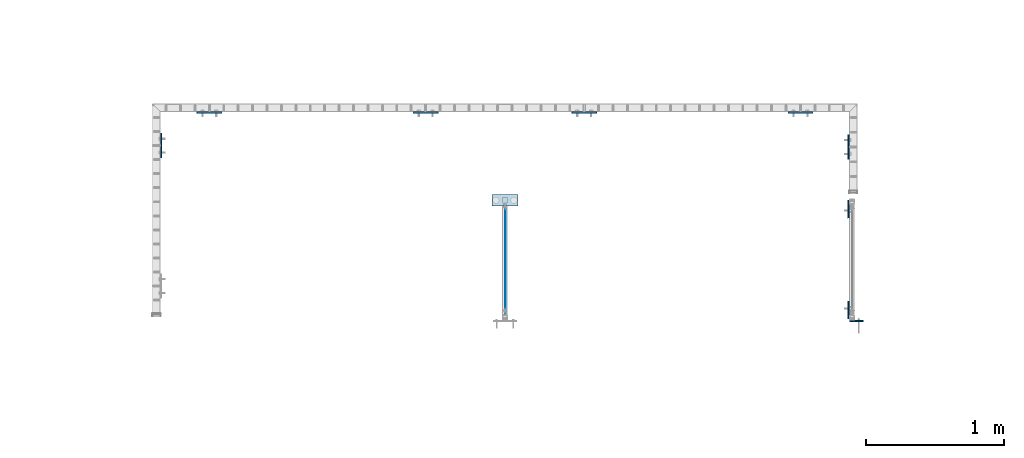
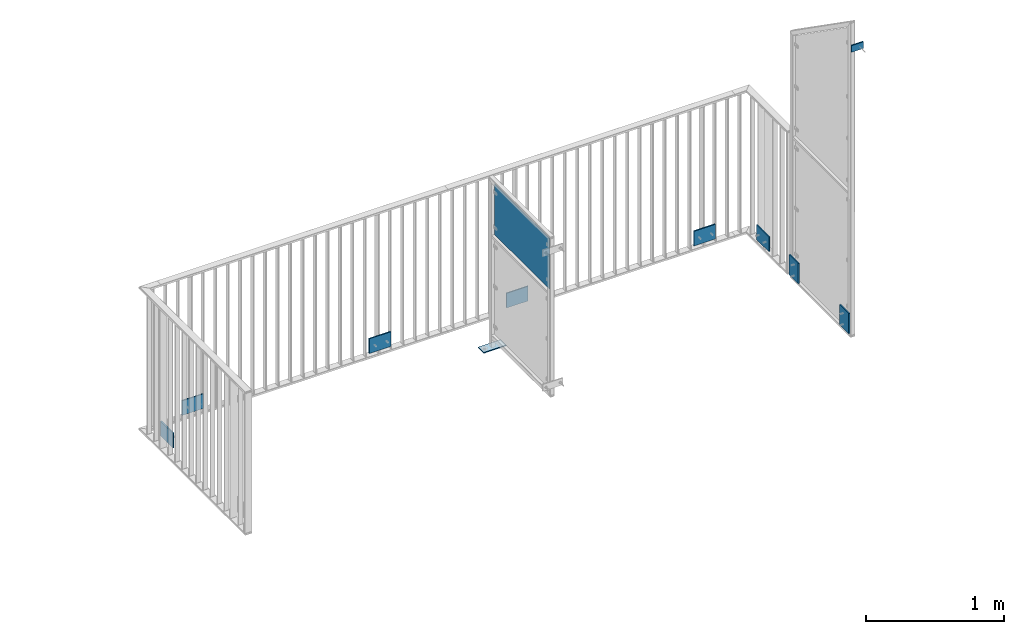
# One storey, part 55 of 156: 11 plates, 7 elements without a shape of their own.
"""IFC2X3 building model written with IfcOpenShell, lengths in millimetres."""

from ifc_helpers import new_model, si_unit, frame, origin_with_axes, origin_2d_with_axis, place, context, subcontext, project, spatial, polyline, rectangle, outline, extrude, material, type_object, element, aggregate, save


model = new_model("IFC2X3")

# Units and contexts
model_context = context("Model", 3, precision=1e-05, world=origin_with_axes())
body_context = subcontext(model_context, "Body", "Model", "MODEL_VIEW")
ifc_project = project(units=[si_unit("LENGTHUNIT", "METRE", prefix="MILLI"), si_unit("AREAUNIT", "SQUARE_METRE"), si_unit("VOLUMEUNIT", "CUBIC_METRE"), si_unit("MASSUNIT", "GRAM", prefix="KILO"), si_unit("TIMEUNIT", "SECOND"), si_unit("PLANEANGLEUNIT", "RADIAN"), si_unit("SOLIDANGLEUNIT", "STERADIAN"), si_unit("THERMODYNAMICTEMPERATUREUNIT", "DEGREE_CELSIUS"), si_unit("LUMINOUSINTENSITYUNIT", "LUMEN")], contexts=[model_context])

# Site, building, storey
site_placement = place(None, origin_with_axes())
site = spatial("IfcSite", under=ifc_project, at=site_placement, CompositionType="ELEMENT")
building_placement = place(site_placement, origin_with_axes())
building = spatial("IfcBuilding", under=site, at=building_placement, Name="Undefined", CompositionType="ELEMENT")
storey_placement = place(building_placement, origin_with_axes())
storey = spatial("IfcBuildingStorey", under=building, at=storey_placement, Name="Undefined", CompositionType="ELEMENT", Elevation=0.0)

# Assembly, plates
assembly_1_placement = place(storey_placement, origin_with_axes())
assembly_1 = element("IfcElementAssembly", 1, at=assembly_1_placement, inside=storey, AssemblyPlace="NOTDEFINED", PredefinedType="RIGID_FRAME")
ifc_material = material(Name="STEEL/S235JR")
plate_type_1 = type_object("IfcPlateType", PredefinedType="NOTDEFINED")
plate_1_placement = place(assembly_1_placement, frame((46089.9972992471, 20192.9949622495, 2942.50385412297), z_axis=(0.0, 0.99999999999886, -1.50999999973318e-06), x_axis=(0.0, -1.7160000020845e-06, -0.999999999998528)))
plate_1 = element("IfcPlate", 2, at=plate_1_placement, type_object=plate_type_1, material=ifc_material, context=body_context, shape_type="SweptSolid", body=[
    extrude(rectangle(XDim=10.0, YDim=130.0, at=origin_2d_with_axis()), frame((180.0, 0.0, 0.0), z_axis=(-1.0, 0.0, 0.0), x_axis=(0.0, -1.0, 0.0)), (0.0, 0.0, 1.0), 180.0),
])
plate_2_placement = place(assembly_1_placement, frame((46089.9972992471, 20923.0050377505, 2942.50385412297), z_axis=(0.0, -0.999999999998528, -1.71599999971061e-06), x_axis=(0.0, 1.73100000029081e-06, -0.999999999998502)))
plate_2 = element("IfcPlate", 3, at=plate_2_placement, type_object=plate_type_1, material=ifc_material, context=body_context, shape_type="SweptSolid", body=[
    extrude(rectangle(XDim=10.0, YDim=130.0, at=origin_2d_with_axis()), frame((180.0, 0.0, 0.0), z_axis=(-1.0, 0.0, 0.0), x_axis=(0.0, -1.0, 0.0)), (0.0, 0.0, 1.0), 180.0),
])

# Assembly, plate
assembly_2_placement = place(storey_placement, origin_with_axes())
assembly_2 = element("IfcElementAssembly", 4, at=assembly_2_placement, inside=storey, AssemblyPlace="NOTDEFINED", PredefinedType="RIGID_FRAME")
plate_3_placement = place(assembly_2_placement, frame((44264.6444496965, 21622.9904480508, 2852.5), z_axis=(0.0, 0.0, 1.0), x_axis=(-1.0, 0.0, 0.0)))
plate_3 = element("IfcPlate", 5, at=plate_3_placement, type_object=plate_type_1, material=ifc_material, context=body_context, shape_type="SweptSolid", body=[
    extrude(rectangle(XDim=10.0, YDim=130.0, at=origin_2d_with_axis()), frame((180.0, 0.0, 0.0), z_axis=(-1.0, 0.0, 0.0), x_axis=(0.0, -1.0, 0.0)), (0.0, 0.0, 1.0), 180.0),
])

# Assembly, plates
assembly_3_placement = place(storey_placement, origin_with_axes())
assembly_3 = element("IfcElementAssembly", 6, at=assembly_3_placement, inside=storey, AssemblyPlace="NOTDEFINED", PredefinedType="RIGID_FRAME")
plate_4_placement = place(assembly_3_placement, frame((43115.3391913749, 21622.9904480508, 2852.5), z_axis=(0.0, 0.0, 1.0), x_axis=(-1.0, 0.0, 0.0)))
plate_4 = element("IfcPlate", 7, at=plate_4_placement, type_object=plate_type_1, material=ifc_material, context=body_context, shape_type="SweptSolid", body=[
    extrude(rectangle(XDim=10.0, YDim=130.0, at=origin_2d_with_axis()), frame((180.0, 0.0, 0.0), z_axis=(-1.0, 0.0, 0.0), x_axis=(0.0, -1.0, 0.0)), (0.0, 0.0, 1.0), 180.0),
])
plate_5_placement = place(assembly_3_placement, frame((41548.3177394654, 21622.9904480508, 2852.5), z_axis=(0.0, 0.0, 1.0), x_axis=(-1.0, 0.0, 0.0)))
plate_5 = element("IfcPlate", 8, at=plate_5_placement, type_object=plate_type_1, material=ifc_material, context=body_context, shape_type="SweptSolid", body=[
    extrude(rectangle(XDim=10.0, YDim=130.0, at=origin_2d_with_axis()), frame((180.0, 0.0, 0.0), z_axis=(-1.0, 0.0, 0.0), x_axis=(0.0, -1.0, 0.0)), (0.0, 0.0, 1.0), 180.0),
])
aggregate(assembly_3, [plate_4, plate_5])

# Assembly, plate
assembly_4_placement = place(storey_placement, origin_with_axes())
assembly_4 = element("IfcElementAssembly", 9, at=assembly_4_placement, inside=storey, AssemblyPlace="NOTDEFINED", PredefinedType="RIGID_FRAME")
plate_6_placement = place(assembly_4_placement, frame((46089.9972992471, 21464.1492182564, 2852.5), z_axis=(0.0, 0.0, 1.0), x_axis=(0.0, -1.0, 0.0)))
plate_6 = element("IfcPlate", 10, at=plate_6_placement, type_object=plate_type_1, material=ifc_material, context=body_context, shape_type="SweptSolid", body=[
    extrude(rectangle(XDim=10.0, YDim=130.0, at=origin_2d_with_axis()), frame((180.0, 0.0, 0.0), z_axis=(-1.0, 0.0, 0.0), x_axis=(0.0, -1.0, 0.0)), (0.0, 0.0, 1.0), 180.0),
])
aggregate(assembly_4, [plate_6])

# Plate
plate_7_placement = place(assembly_2_placement, frame((45831.665901606, 21622.9904480508, 2852.5), z_axis=(0.0, 0.0, 1.0), x_axis=(-1.0, 0.0, 0.0)))
plate_7 = element("IfcPlate", 11, at=plate_7_placement, type_object=plate_type_1, material=ifc_material, context=body_context, shape_type="SweptSolid", body=[
    extrude(rectangle(XDim=10.0, YDim=130.0, at=origin_2d_with_axis()), frame((180.0, 0.0, 0.0), z_axis=(-1.0, 0.0, 0.0), x_axis=(0.0, -1.0, 0.0)), (0.0, 0.0, 1.0), 180.0),
])

aggregate(assembly_2, [plate_3, plate_7])

# Assembly, plate
assembly_5_placement = place(storey_placement, origin_with_axes())
assembly_5 = element("IfcElementAssembly", 12, at=assembly_5_placement, inside=storey, AssemblyPlace="NOTDEFINED", PredefinedType="RIGID_FRAME")
plate_8_placement = place(assembly_5_placement, frame((41109.9973601768, 21474.4292182564, 2852.5), z_axis=(0.0, 0.0, 1.0), x_axis=(0.0, -1.0, 0.0)))
plate_8 = element("IfcPlate", 13, at=plate_8_placement, type_object=plate_type_1, material=ifc_material, context=body_context, shape_type="SweptSolid", body=[
    extrude(rectangle(XDim=10.0, YDim=130.0, at=origin_2d_with_axis()), frame((180.0, 0.0, 0.0), z_axis=(-1.0, 0.0, 0.0), x_axis=(0.0, -1.0, 0.0)), (0.0, 0.0, 1.0), 180.0),
])
aggregate(assembly_5, [plate_8])

assembly_6_placement = place(storey_placement, origin_with_axes())
assembly_6 = element("IfcElementAssembly", 14, at=assembly_6_placement, inside=storey, AssemblyPlace="NOTDEFINED", PredefinedType="RIGID_FRAME")
plate_type_2 = type_object("IfcPlateType", PredefinedType="NOTDEFINED")
plate_9_placement = place(assembly_6_placement, frame((43504.9990081787, 20988.2563982149, 2998.99577404583), z_axis=(0.0, -0.000195990999960145, 0.999999980793764), x_axis=(1.0, 0.0, 0.0)))
plate_9 = element("IfcPlate", 15, at=plate_9_placement, type_object=plate_type_2, material=ifc_material, context=body_context, shape_type="SweptSolid", body=[
    extrude(outline(polyline([(0.0, -40.0000000001091), (0.0, 40.0000000001091), (190.0, 40.0000000001091), (190.0, -40.0000000001091), (0.0, -40.0000000001091)])), frame((0.0, 0.0, -4.0), z_axis=(0.0, 0.0, 1.0), x_axis=(1.0, 0.0, 0.0)), (0.0, 0.0, 1.0), 8.0),
])
aggregate(assembly_6, [plate_9])

# Plate
plate_type_3 = type_object("IfcPlateType", PredefinedType="NOTDEFINED")
plate_10_placement = place(assembly_1_placement, frame((46197.9944458008, 20113.4517003402, 5289.3099999525), z_axis=(0.0, 0.0, 1.0), x_axis=(-1.0, 0.0, 0.0)))
plate_10 = element("IfcPlate", 16, at=plate_10_placement, type_object=plate_type_3, material=ifc_material, context=body_context, shape_type="SweptSolid", body=[
    extrude(rectangle(XDim=10.0, YDim=60.0, at=origin_2d_with_axis()), frame((100.0, 0.0, 0.0), z_axis=(-1.0, 0.0, 0.0), x_axis=(0.0, -1.0, 0.0)), (0.0, 0.0, 1.0), 100.0),
])

aggregate(assembly_1, [plate_10, plate_1, plate_2])

# Assembly, plate
assembly_7_placement = place(storey_placement, origin_with_axes())
assembly_7 = element("IfcElementAssembly", 17, at=assembly_7_placement, inside=storey, AssemblyPlace="NOTDEFINED", PredefinedType="RIGID_FRAME")
plate_type_4 = type_object("IfcPlateType", PredefinedType="NOTDEFINED")
plate_11_placement = place(assembly_7_placement, frame((43603.9990081787, 20162.9561211043, 4229.99878707759), z_axis=(0.0, 0.0, 1.0), x_axis=(0.0, 1.0, 0.0)))
plate_11 = element("IfcPlate", 18, at=plate_11_placement, type_object=plate_type_4, material=ifc_material, context=body_context, shape_type="SweptSolid", body=[
    extrude(rectangle(XDim=3.0, YDim=450.0, at=origin_2d_with_axis()), frame((800.050991195178, 0.0, 0.0), z_axis=(-1.0, 0.0, 0.0), x_axis=(0.0, -1.0, 0.0)), (0.0, 0.0, 1.0), 800.05),
])
aggregate(assembly_7, [plate_11])

save(model, "model.ifc")
